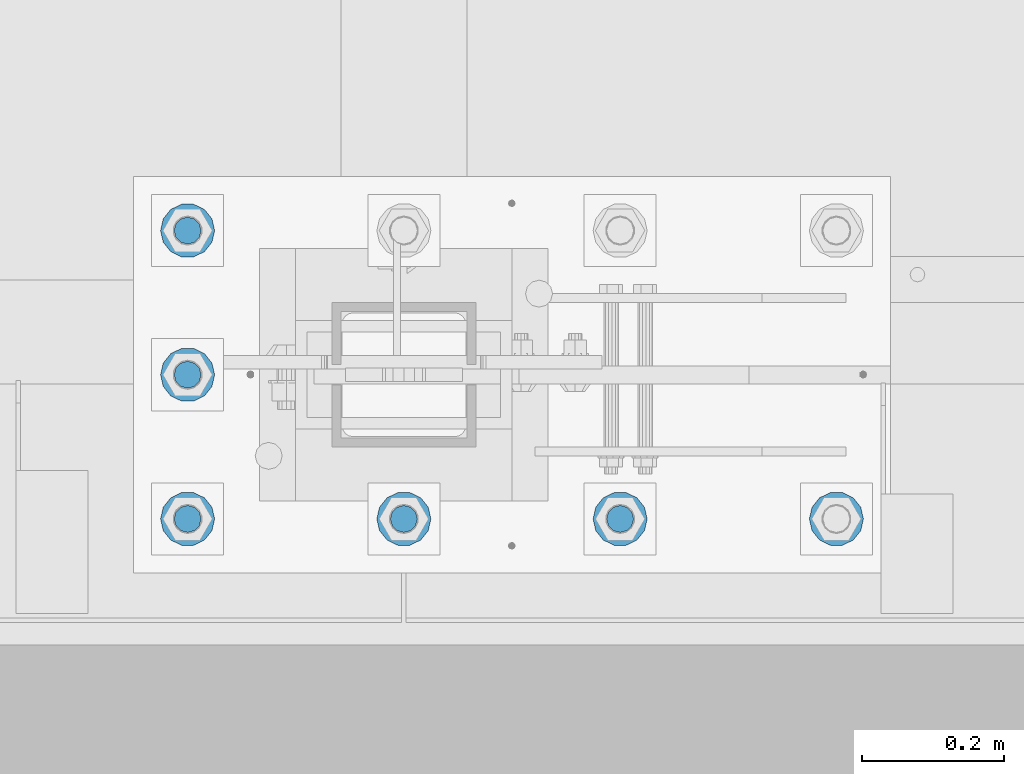
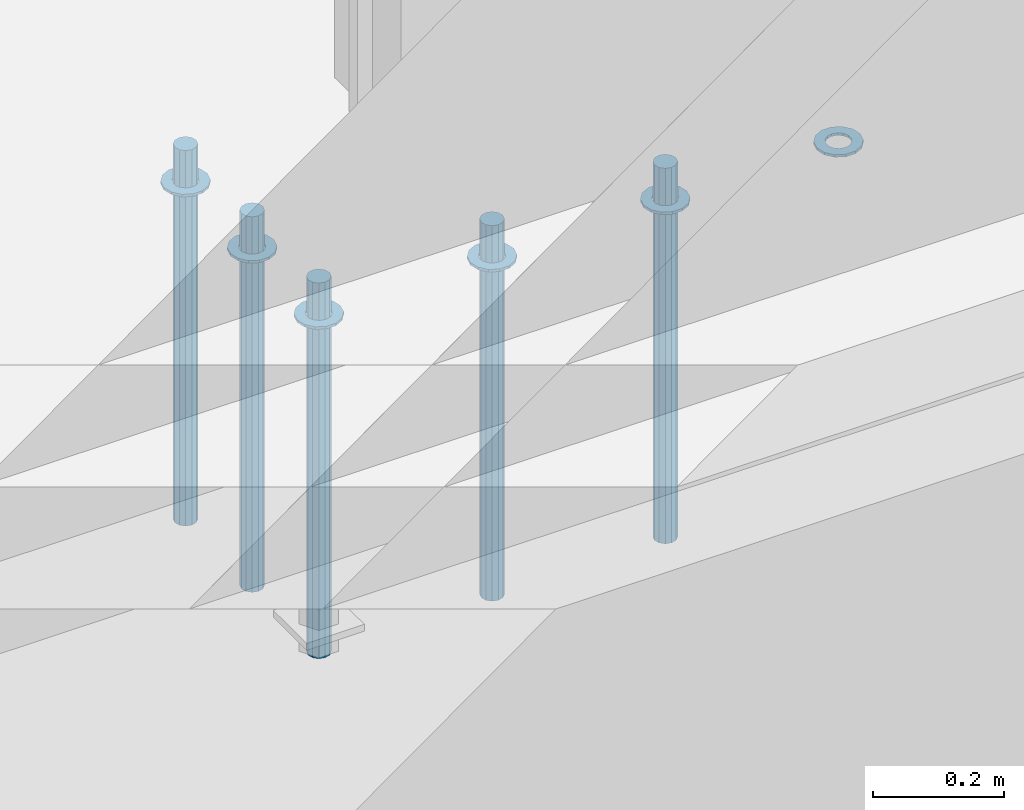
# One storey, part 931 of 1763: 11 columns, 1 element without a shape of its own.
"""IFC2X3 building model written with IfcOpenShell, lengths in millimetres."""

from ifc_helpers import new_model, si_unit, frame, origin_with_axes, place, context, subcontext, project, spatial, faceted_brep, material, type_object, element, aggregate, save


model = new_model("IFC2X3")

# Units and contexts
model_context = context("Model", 3, precision=1e-05, world=origin_with_axes())
body_context = subcontext(model_context, "Body", "Model", "MODEL_VIEW")
ifc_project = project(units=[si_unit("LENGTHUNIT", "METRE", prefix="MILLI"), si_unit("AREAUNIT", "SQUARE_METRE"), si_unit("VOLUMEUNIT", "CUBIC_METRE"), si_unit("MASSUNIT", "GRAM", prefix="KILO"), si_unit("TIMEUNIT", "SECOND"), si_unit("PLANEANGLEUNIT", "RADIAN"), si_unit("SOLIDANGLEUNIT", "STERADIAN"), si_unit("THERMODYNAMICTEMPERATUREUNIT", "DEGREE_CELSIUS"), si_unit("LUMINOUSINTENSITYUNIT", "LUMEN")], contexts=[model_context])

# Site, building, storey
site_placement = place(None, origin_with_axes())
site = spatial("IfcSite", under=ifc_project, at=site_placement, CompositionType="ELEMENT")
building_placement = place(site_placement, origin_with_axes())
building = spatial("IfcBuilding", under=site, at=building_placement, Name="Undefined", CompositionType="ELEMENT")
storey_placement = place(building_placement, origin_with_axes())
storey = spatial("IfcBuildingStorey", under=building, at=storey_placement, Name="Undefined", CompositionType="ELEMENT", Elevation=0.0)

# Assembly, columns
assembly_placement = place(storey_placement, origin_with_axes())
assembly = element("IfcElementAssembly", 1, at=assembly_placement, inside=storey, Name="TEMPLATE", AssemblyPlace="NOTDEFINED", PredefinedType="RIGID_FRAME")
ifc_material_1 = material(Name="STEEL/F436")
column_type_1 = type_object("IfcColumnType", Name="1-1/2_WASHER", PredefinedType="NOTDEFINED")
column_1_placement = place(assembly_placement, frame((-35254.6372736983, -13919.2, 5151.4375), z_axis=(0.0, -1.0, 0.0), x_axis=(0.0, 0.0, -1.0)))
column_1 = element("IfcColumn", 2, at=column_1_placement, type_object=column_type_1, material=ifc_material_1, Name="WASHER", ObjectType="1-1/2_WASHER", context=body_context, shape_type="Brep", body=[
    faceted_brep([(0.0, -38.0999984741211, 0.0), (0.0, -34.3269124923099, -16.5309697983248), (4.76249999999982, -34.3269124923099, -16.5309697983248), (4.76249999999982, -38.0999984741211, 0.0), (0.0, -23.7549604994492, -29.7877782890519), (4.76249999999982, -23.7549604994492, -29.7877782890519), (0.0, -8.47804724419257, -37.1447519665053), (4.76249999999982, -8.47804724419257, -37.1447519665053), (0.0, 8.47804724419257, -37.1447519665053), (4.76249999999982, 8.47804724419257, -37.1447519665053), (0.0, 23.7549604994492, -29.7877782890519), (4.76249999999982, 23.7549604994492, -29.7877782890519), (0.0, 34.3269124923099, -16.5309697983248), (4.76249999999982, 34.3269124923099, -16.5309697983248), (0.0, 38.0999984741211, 0.0), (4.76249999999982, 38.0999984741211, 0.0), (0.0, 34.3269124923099, 16.5309697983248), (4.76249999999982, 34.3269124923099, 16.5309697983248), (0.0, 23.7549604994492, 29.7877782890519), (4.76249999999982, 23.7549604994492, 29.7877782890519), (0.0, 8.47804724419257, 37.1447519665053), (4.76249999999982, 8.47804724419257, 37.1447519665053), (0.0, -8.47804724419257, 37.1447519665053), (4.76249999999982, -8.47804724419257, 37.1447519665053), (0.0, -23.7549604994492, 29.7877782890519), (4.76249999999982, -23.7549604994492, 29.7877782890519), (0.0, -34.3269124923099, 16.5309697983248), (4.76249999999982, -34.3269124923099, 16.5309697983248), (0.0, 0.0, 20.6399993896484), (0.0, 8.95536011056538, 18.5959968835978), (4.76249999999982, 8.95536011056538, 18.5959968835978), (4.76249999999982, 0.0, 20.6399993896484), (0.0, 16.1370013209453, 12.8688291298167), (4.76249999999982, 16.1370013209453, 12.8688291298167), (0.0, 20.1225115123816, 4.59283194104137), (4.76249999999982, 20.1225115123816, 4.59283194104137), (0.0, 20.1225115123816, -4.59283194104319), (4.76249999999982, 20.1225115123816, -4.59283194104319), (0.0, 16.1370013209453, -12.8688291298167), (4.76249999999982, 16.1370013209453, -12.8688291298167), (0.0, 8.95536011056538, -18.5959968835978), (4.76249999999982, 8.95536011056538, -18.5959968835978), (0.0, 0.0, -20.6399993896484), (4.76249999999982, 0.0, -20.6399993896484), (0.0, -8.95536011056538, -18.5959968835978), (4.76249999999982, -8.95536011056538, -18.5959968835978), (0.0, -16.1370013209453, -12.8688291298167), (4.76249999999982, -16.1370013209453, -12.8688291298167), (0.0, -20.1225115123816, -4.59283194104137), (4.76249999999982, -20.1225115123816, -4.59283194104137), (0.0, -20.1225115123816, 4.59283194104319), (4.76249999999982, -20.1225115123816, 4.59283194104319), (0.0, -16.1370013209453, 12.8688291298167), (4.76249999999982, -16.1370013209453, 12.8688291298167), (0.0, -8.95536011056538, 18.5959968835978), (4.76249999999982, -8.95536011056538, 18.5959968835978)], [[[0, 1, 2, 3]], [[1, 4, 5, 2]], [[4, 6, 7, 5]], [[6, 8, 9, 7]], [[8, 10, 11, 9]], [[10, 12, 13, 11]], [[12, 14, 15, 13]], [[14, 16, 17, 15]], [[16, 18, 19, 17]], [[18, 20, 21, 19]], [[20, 22, 23, 21]], [[22, 24, 25, 23]], [[24, 26, 27, 25]], [[26, 0, 3, 27]], [[28, 29, 30, 31]], [[29, 32, 33, 30]], [[32, 34, 35, 33]], [[34, 36, 37, 35]], [[36, 38, 39, 37]], [[38, 40, 41, 39]], [[40, 42, 43, 41]], [[42, 44, 45, 43]], [[44, 46, 47, 45]], [[46, 48, 49, 47]], [[48, 50, 51, 49]], [[50, 52, 53, 51]], [[52, 54, 55, 53]], [[54, 28, 31, 55]], [[5, 7, 9, 11, 13, 15, 17, 19, 21, 23, 25, 27, 3, 2], [33, 35, 37, 39, 41, 43, 45, 47, 49, 51, 53, 55, 31, 30]], [[26, 24, 22, 20, 18, 16, 14, 12, 10, 8, 6, 4, 1, 0], [54, 52, 50, 48, 46, 44, 42, 40, 38, 36, 34, 32, 29, 28]]]),
])
column_2_placement = place(assembly_placement, frame((-34949.8372736984, -13919.2, 5151.4375), z_axis=(0.0, -1.0, 0.0), x_axis=(0.0, 0.0, -1.0)))
column_2 = element("IfcColumn", 3, at=column_2_placement, type_object=column_type_1, material=ifc_material_1, Name="WASHER", ObjectType="1-1/2_WASHER", context=body_context, shape_type="Brep", body=[
    faceted_brep([(0.0, -38.0999984741211, 0.0), (0.0, -34.3269124923099, -16.5309697983248), (4.76249999999982, -34.3269124923099, -16.5309697983248), (4.76249999999982, -38.0999984741211, 0.0), (0.0, -23.7549604994492, -29.7877782890519), (4.76249999999982, -23.7549604994492, -29.7877782890519), (0.0, -8.47804724419257, -37.1447519665053), (4.76249999999982, -8.47804724419257, -37.1447519665053), (0.0, 8.47804724419257, -37.1447519665053), (4.76249999999982, 8.47804724419257, -37.1447519665053), (0.0, 23.7549604994492, -29.7877782890519), (4.76249999999982, 23.7549604994492, -29.7877782890519), (0.0, 34.3269124923099, -16.5309697983248), (4.76249999999982, 34.3269124923099, -16.5309697983248), (0.0, 38.0999984741211, 0.0), (4.76249999999982, 38.0999984741211, 0.0), (0.0, 34.3269124923099, 16.5309697983248), (4.76249999999982, 34.3269124923099, 16.5309697983248), (0.0, 23.7549604994492, 29.7877782890519), (4.76249999999982, 23.7549604994492, 29.7877782890519), (0.0, 8.47804724419257, 37.1447519665053), (4.76249999999982, 8.47804724419257, 37.1447519665053), (0.0, -8.47804724419257, 37.1447519665053), (4.76249999999982, -8.47804724419257, 37.1447519665053), (0.0, -23.7549604994492, 29.7877782890519), (4.76249999999982, -23.7549604994492, 29.7877782890519), (0.0, -34.3269124923099, 16.5309697983248), (4.76249999999982, -34.3269124923099, 16.5309697983248), (0.0, 0.0, 20.6399993896484), (0.0, 8.95536011056538, 18.5959968835978), (4.76249999999982, 8.95536011056538, 18.5959968835978), (4.76249999999982, 0.0, 20.6399993896484), (0.0, 16.1370013209453, 12.8688291298167), (4.76249999999982, 16.1370013209453, 12.8688291298167), (0.0, 20.1225115123816, 4.59283194104137), (4.76249999999982, 20.1225115123816, 4.59283194104137), (0.0, 20.1225115123816, -4.59283194104319), (4.76249999999982, 20.1225115123816, -4.59283194104319), (0.0, 16.1370013209453, -12.8688291298167), (4.76249999999982, 16.1370013209453, -12.8688291298167), (0.0, 8.95536011056538, -18.5959968835978), (4.76249999999982, 8.95536011056538, -18.5959968835978), (0.0, 0.0, -20.6399993896484), (4.76249999999982, 0.0, -20.6399993896484), (0.0, -8.95536011056538, -18.5959968835978), (4.76249999999982, -8.95536011056538, -18.5959968835978), (0.0, -16.1370013209453, -12.8688291298167), (4.76249999999982, -16.1370013209453, -12.8688291298167), (0.0, -20.1225115123816, -4.59283194104137), (4.76249999999982, -20.1225115123816, -4.59283194104137), (0.0, -20.1225115123816, 4.59283194104319), (4.76249999999982, -20.1225115123816, 4.59283194104319), (0.0, -16.1370013209453, 12.8688291298167), (4.76249999999982, -16.1370013209453, 12.8688291298167), (0.0, -8.95536011056538, 18.5959968835978), (4.76249999999982, -8.95536011056538, 18.5959968835978)], [[[0, 1, 2, 3]], [[1, 4, 5, 2]], [[4, 6, 7, 5]], [[6, 8, 9, 7]], [[8, 10, 11, 9]], [[10, 12, 13, 11]], [[12, 14, 15, 13]], [[14, 16, 17, 15]], [[16, 18, 19, 17]], [[18, 20, 21, 19]], [[20, 22, 23, 21]], [[22, 24, 25, 23]], [[24, 26, 27, 25]], [[26, 0, 3, 27]], [[28, 29, 30, 31]], [[29, 32, 33, 30]], [[32, 34, 35, 33]], [[34, 36, 37, 35]], [[36, 38, 39, 37]], [[38, 40, 41, 39]], [[40, 42, 43, 41]], [[42, 44, 45, 43]], [[44, 46, 47, 45]], [[46, 48, 49, 47]], [[48, 50, 51, 49]], [[50, 52, 53, 51]], [[52, 54, 55, 53]], [[54, 28, 31, 55]], [[5, 7, 9, 11, 13, 15, 17, 19, 21, 23, 25, 27, 3, 2], [33, 35, 37, 39, 41, 43, 45, 47, 49, 51, 53, 55, 31, 30]], [[26, 24, 22, 20, 18, 16, 14, 12, 10, 8, 6, 4, 1, 0], [54, 52, 50, 48, 46, 44, 42, 40, 38, 36, 34, 32, 29, 28]]]),
])
column_3_placement = place(assembly_placement, frame((-34645.0372736983, -13919.2, 5151.4375), z_axis=(0.0, 1.0, 0.0), x_axis=(0.0, 0.0, -1.0)))
column_3 = element("IfcColumn", 4, at=column_3_placement, type_object=column_type_1, material=ifc_material_1, Name="WASHER", ObjectType="1-1/2_WASHER", context=body_context, shape_type="Brep", body=[
    faceted_brep([(0.0, -38.0999984741211, 0.0), (0.0, -34.3269124923099, -16.5309697983248), (4.76249999999982, -34.3269124923099, -16.5309697983248), (4.76249999999982, -38.0999984741211, 0.0), (0.0, -23.7549604994492, -29.7877782890519), (4.76249999999982, -23.7549604994492, -29.7877782890519), (0.0, -8.47804724419257, -37.1447519665053), (4.76249999999982, -8.47804724419257, -37.1447519665053), (0.0, 8.47804724419257, -37.1447519665053), (4.76249999999982, 8.47804724419257, -37.1447519665053), (0.0, 23.7549604994492, -29.7877782890519), (4.76249999999982, 23.7549604994492, -29.7877782890519), (0.0, 34.3269124923099, -16.5309697983248), (4.76249999999982, 34.3269124923099, -16.5309697983248), (0.0, 38.0999984741211, 0.0), (4.76249999999982, 38.0999984741211, 0.0), (0.0, 34.3269124923099, 16.5309697983248), (4.76249999999982, 34.3269124923099, 16.5309697983248), (0.0, 23.7549604994492, 29.7877782890519), (4.76249999999982, 23.7549604994492, 29.7877782890519), (0.0, 8.47804724419257, 37.1447519665053), (4.76249999999982, 8.47804724419257, 37.1447519665053), (0.0, -8.47804724419257, 37.1447519665053), (4.76249999999982, -8.47804724419257, 37.1447519665053), (0.0, -23.7549604994492, 29.7877782890519), (4.76249999999982, -23.7549604994492, 29.7877782890519), (0.0, -34.3269124923099, 16.5309697983248), (4.76249999999982, -34.3269124923099, 16.5309697983248), (0.0, 0.0, 20.6399993896484), (0.0, 8.95536011056538, 18.5959968835978), (4.76249999999982, 8.95536011056538, 18.5959968835978), (4.76249999999982, 0.0, 20.6399993896484), (0.0, 16.1370013209453, 12.8688291298167), (4.76249999999982, 16.1370013209453, 12.8688291298167), (0.0, 20.1225115123816, 4.59283194104137), (4.76249999999982, 20.1225115123816, 4.59283194104137), (0.0, 20.1225115123816, -4.59283194104319), (4.76249999999982, 20.1225115123816, -4.59283194104319), (0.0, 16.1370013209453, -12.8688291298167), (4.76249999999982, 16.1370013209453, -12.8688291298167), (0.0, 8.95536011056538, -18.5959968835978), (4.76249999999982, 8.95536011056538, -18.5959968835978), (0.0, 0.0, -20.6399993896484), (4.76249999999982, 0.0, -20.6399993896484), (0.0, -8.95536011056538, -18.5959968835978), (4.76249999999982, -8.95536011056538, -18.5959968835978), (0.0, -16.1370013209453, -12.8688291298167), (4.76249999999982, -16.1370013209453, -12.8688291298167), (0.0, -20.1225115123816, -4.59283194104137), (4.76249999999982, -20.1225115123816, -4.59283194104137), (0.0, -20.1225115123816, 4.59283194104319), (4.76249999999982, -20.1225115123816, 4.59283194104319), (0.0, -16.1370013209453, 12.8688291298167), (4.76249999999982, -16.1370013209453, 12.8688291298167), (0.0, -8.95536011056538, 18.5959968835978), (4.76249999999982, -8.95536011056538, 18.5959968835978)], [[[0, 1, 2, 3]], [[1, 4, 5, 2]], [[4, 6, 7, 5]], [[6, 8, 9, 7]], [[8, 10, 11, 9]], [[10, 12, 13, 11]], [[12, 14, 15, 13]], [[14, 16, 17, 15]], [[16, 18, 19, 17]], [[18, 20, 21, 19]], [[20, 22, 23, 21]], [[22, 24, 25, 23]], [[24, 26, 27, 25]], [[26, 0, 3, 27]], [[28, 29, 30, 31]], [[29, 32, 33, 30]], [[32, 34, 35, 33]], [[34, 36, 37, 35]], [[36, 38, 39, 37]], [[38, 40, 41, 39]], [[40, 42, 43, 41]], [[42, 44, 45, 43]], [[44, 46, 47, 45]], [[46, 48, 49, 47]], [[48, 50, 51, 49]], [[50, 52, 53, 51]], [[52, 54, 55, 53]], [[54, 28, 31, 55]], [[5, 7, 9, 11, 13, 15, 17, 19, 21, 23, 25, 27, 3, 2], [33, 35, 37, 39, 41, 43, 45, 47, 49, 51, 53, 55, 31, 30]], [[26, 24, 22, 20, 18, 16, 14, 12, 10, 8, 6, 4, 1, 0], [54, 52, 50, 48, 46, 44, 42, 40, 38, 36, 34, 32, 29, 28]]]),
])
column_4_placement = place(assembly_placement, frame((-34340.2372736983, -13919.2, 5151.4375), z_axis=(0.0, 1.0, 0.0), x_axis=(0.0, 0.0, -1.0)))
column_4 = element("IfcColumn", 5, at=column_4_placement, type_object=column_type_1, material=ifc_material_1, Name="WASHER", ObjectType="1-1/2_WASHER", context=body_context, shape_type="Brep", body=[
    faceted_brep([(0.0, -38.0999984741211, 0.0), (0.0, -34.3269124923099, -16.5309697983248), (4.76249999999982, -34.3269124923099, -16.5309697983248), (4.76249999999982, -38.0999984741211, 0.0), (0.0, -23.7549604994492, -29.7877782890519), (4.76249999999982, -23.7549604994492, -29.7877782890519), (0.0, -8.47804724419257, -37.1447519665053), (4.76249999999982, -8.47804724419257, -37.1447519665053), (0.0, 8.47804724419257, -37.1447519665053), (4.76249999999982, 8.47804724419257, -37.1447519665053), (0.0, 23.7549604994492, -29.7877782890519), (4.76249999999982, 23.7549604994492, -29.7877782890519), (0.0, 34.3269124923099, -16.5309697983248), (4.76249999999982, 34.3269124923099, -16.5309697983248), (0.0, 38.0999984741211, 0.0), (4.76249999999982, 38.0999984741211, 0.0), (0.0, 34.3269124923099, 16.5309697983248), (4.76249999999982, 34.3269124923099, 16.5309697983248), (0.0, 23.7549604994492, 29.7877782890519), (4.76249999999982, 23.7549604994492, 29.7877782890519), (0.0, 8.47804724419257, 37.1447519665053), (4.76249999999982, 8.47804724419257, 37.1447519665053), (0.0, -8.47804724419257, 37.1447519665053), (4.76249999999982, -8.47804724419257, 37.1447519665053), (0.0, -23.7549604994492, 29.7877782890519), (4.76249999999982, -23.7549604994492, 29.7877782890519), (0.0, -34.3269124923099, 16.5309697983248), (4.76249999999982, -34.3269124923099, 16.5309697983248), (0.0, 0.0, 20.6399993896484), (0.0, 8.95536011056538, 18.5959968835978), (4.76249999999982, 8.95536011056538, 18.5959968835978), (4.76249999999982, 0.0, 20.6399993896484), (0.0, 16.1370013209453, 12.8688291298167), (4.76249999999982, 16.1370013209453, 12.8688291298167), (0.0, 20.1225115123816, 4.59283194104137), (4.76249999999982, 20.1225115123816, 4.59283194104137), (0.0, 20.1225115123816, -4.59283194104319), (4.76249999999982, 20.1225115123816, -4.59283194104319), (0.0, 16.1370013209453, -12.8688291298167), (4.76249999999982, 16.1370013209453, -12.8688291298167), (0.0, 8.95536011056538, -18.5959968835978), (4.76249999999982, 8.95536011056538, -18.5959968835978), (0.0, 0.0, -20.6399993896484), (4.76249999999982, 0.0, -20.6399993896484), (0.0, -8.95536011056538, -18.5959968835978), (4.76249999999982, -8.95536011056538, -18.5959968835978), (0.0, -16.1370013209453, -12.8688291298167), (4.76249999999982, -16.1370013209453, -12.8688291298167), (0.0, -20.1225115123816, -4.59283194104137), (4.76249999999982, -20.1225115123816, -4.59283194104137), (0.0, -20.1225115123816, 4.59283194104319), (4.76249999999982, -20.1225115123816, 4.59283194104319), (0.0, -16.1370013209453, 12.8688291298167), (4.76249999999982, -16.1370013209453, 12.8688291298167), (0.0, -8.95536011056538, 18.5959968835978), (4.76249999999982, -8.95536011056538, 18.5959968835978)], [[[0, 1, 2, 3]], [[1, 4, 5, 2]], [[4, 6, 7, 5]], [[6, 8, 9, 7]], [[8, 10, 11, 9]], [[10, 12, 13, 11]], [[12, 14, 15, 13]], [[14, 16, 17, 15]], [[16, 18, 19, 17]], [[18, 20, 21, 19]], [[20, 22, 23, 21]], [[22, 24, 25, 23]], [[24, 26, 27, 25]], [[26, 0, 3, 27]], [[28, 29, 30, 31]], [[29, 32, 33, 30]], [[32, 34, 35, 33]], [[34, 36, 37, 35]], [[36, 38, 39, 37]], [[38, 40, 41, 39]], [[40, 42, 43, 41]], [[42, 44, 45, 43]], [[44, 46, 47, 45]], [[46, 48, 49, 47]], [[48, 50, 51, 49]], [[50, 52, 53, 51]], [[52, 54, 55, 53]], [[54, 28, 31, 55]], [[5, 7, 9, 11, 13, 15, 17, 19, 21, 23, 25, 27, 3, 2], [33, 35, 37, 39, 41, 43, 45, 47, 49, 51, 53, 55, 31, 30]], [[26, 24, 22, 20, 18, 16, 14, 12, 10, 8, 6, 4, 1, 0], [54, 52, 50, 48, 46, 44, 42, 40, 38, 36, 34, 32, 29, 28]]]),
])
column_5_placement = place(assembly_placement, frame((-35254.6372736983, -13716.0, 5151.4375), z_axis=(0.0, -1.0, 0.0), x_axis=(0.0, 0.0, -1.0)))
column_5 = element("IfcColumn", 6, at=column_5_placement, type_object=column_type_1, material=ifc_material_1, Name="WASHER", ObjectType="1-1/2_WASHER", context=body_context, shape_type="Brep", body=[
    faceted_brep([(0.0, -38.0999984741211, 0.0), (0.0, -34.3269124923099, -16.5309697983248), (4.76249999999982, -34.3269124923099, -16.5309697983248), (4.76249999999982, -38.0999984741211, 0.0), (0.0, -23.7549604994492, -29.7877782890519), (4.76249999999982, -23.7549604994492, -29.7877782890519), (0.0, -8.47804724419257, -37.1447519665053), (4.76249999999982, -8.47804724419257, -37.1447519665053), (0.0, 8.47804724419257, -37.1447519665053), (4.76249999999982, 8.47804724419257, -37.1447519665053), (0.0, 23.7549604994492, -29.7877782890519), (4.76249999999982, 23.7549604994492, -29.7877782890519), (0.0, 34.3269124923099, -16.5309697983248), (4.76249999999982, 34.3269124923099, -16.5309697983248), (0.0, 38.0999984741211, 0.0), (4.76249999999982, 38.0999984741211, 0.0), (0.0, 34.3269124923099, 16.5309697983248), (4.76249999999982, 34.3269124923099, 16.5309697983248), (0.0, 23.7549604994492, 29.7877782890519), (4.76249999999982, 23.7549604994492, 29.7877782890519), (0.0, 8.47804724419257, 37.1447519665053), (4.76249999999982, 8.47804724419257, 37.1447519665053), (0.0, -8.47804724419257, 37.1447519665053), (4.76249999999982, -8.47804724419257, 37.1447519665053), (0.0, -23.7549604994492, 29.7877782890519), (4.76249999999982, -23.7549604994492, 29.7877782890519), (0.0, -34.3269124923099, 16.5309697983248), (4.76249999999982, -34.3269124923099, 16.5309697983248), (0.0, 0.0, 20.6399993896484), (0.0, 8.95536011056538, 18.5959968835978), (4.76249999999982, 8.95536011056538, 18.5959968835978), (4.76249999999982, 0.0, 20.6399993896484), (0.0, 16.1370013209453, 12.8688291298167), (4.76249999999982, 16.1370013209453, 12.8688291298167), (0.0, 20.1225115123816, 4.59283194104137), (4.76249999999982, 20.1225115123816, 4.59283194104137), (0.0, 20.1225115123816, -4.59283194104319), (4.76249999999982, 20.1225115123816, -4.59283194104319), (0.0, 16.1370013209453, -12.8688291298167), (4.76249999999982, 16.1370013209453, -12.8688291298167), (0.0, 8.95536011056538, -18.5959968835978), (4.76249999999982, 8.95536011056538, -18.5959968835978), (0.0, 0.0, -20.6399993896484), (4.76249999999982, 0.0, -20.6399993896484), (0.0, -8.95536011056538, -18.5959968835978), (4.76249999999982, -8.95536011056538, -18.5959968835978), (0.0, -16.1370013209453, -12.8688291298167), (4.76249999999982, -16.1370013209453, -12.8688291298167), (0.0, -20.1225115123816, -4.59283194104137), (4.76249999999982, -20.1225115123816, -4.59283194104137), (0.0, -20.1225115123816, 4.59283194104319), (4.76249999999982, -20.1225115123816, 4.59283194104319), (0.0, -16.1370013209453, 12.8688291298167), (4.76249999999982, -16.1370013209453, 12.8688291298167), (0.0, -8.95536011056538, 18.5959968835978), (4.76249999999982, -8.95536011056538, 18.5959968835978)], [[[0, 1, 2, 3]], [[1, 4, 5, 2]], [[4, 6, 7, 5]], [[6, 8, 9, 7]], [[8, 10, 11, 9]], [[10, 12, 13, 11]], [[12, 14, 15, 13]], [[14, 16, 17, 15]], [[16, 18, 19, 17]], [[18, 20, 21, 19]], [[20, 22, 23, 21]], [[22, 24, 25, 23]], [[24, 26, 27, 25]], [[26, 0, 3, 27]], [[28, 29, 30, 31]], [[29, 32, 33, 30]], [[32, 34, 35, 33]], [[34, 36, 37, 35]], [[36, 38, 39, 37]], [[38, 40, 41, 39]], [[40, 42, 43, 41]], [[42, 44, 45, 43]], [[44, 46, 47, 45]], [[46, 48, 49, 47]], [[48, 50, 51, 49]], [[50, 52, 53, 51]], [[52, 54, 55, 53]], [[54, 28, 31, 55]], [[5, 7, 9, 11, 13, 15, 17, 19, 21, 23, 25, 27, 3, 2], [33, 35, 37, 39, 41, 43, 45, 47, 49, 51, 53, 55, 31, 30]], [[26, 24, 22, 20, 18, 16, 14, 12, 10, 8, 6, 4, 1, 0], [54, 52, 50, 48, 46, 44, 42, 40, 38, 36, 34, 32, 29, 28]]]),
])
column_6_placement = place(assembly_placement, frame((-35254.6372736983, -13512.8, 5151.4375), z_axis=(0.0, -1.0, 0.0), x_axis=(0.0, 0.0, -1.0)))
column_6 = element("IfcColumn", 7, at=column_6_placement, type_object=column_type_1, material=ifc_material_1, Name="WASHER", ObjectType="1-1/2_WASHER", context=body_context, shape_type="Brep", body=[
    faceted_brep([(0.0, -38.0999984741211, 0.0), (0.0, -34.3269124923099, -16.5309697983248), (4.76249999999982, -34.3269124923099, -16.5309697983248), (4.76249999999982, -38.0999984741211, 0.0), (0.0, -23.7549604994492, -29.7877782890519), (4.76249999999982, -23.7549604994492, -29.7877782890519), (0.0, -8.47804724419257, -37.1447519665053), (4.76249999999982, -8.47804724419257, -37.1447519665053), (0.0, 8.47804724419257, -37.1447519665053), (4.76249999999982, 8.47804724419257, -37.1447519665053), (0.0, 23.7549604994492, -29.7877782890519), (4.76249999999982, 23.7549604994492, -29.7877782890519), (0.0, 34.3269124923099, -16.5309697983248), (4.76249999999982, 34.3269124923099, -16.5309697983248), (0.0, 38.0999984741211, 0.0), (4.76249999999982, 38.0999984741211, 0.0), (0.0, 34.3269124923099, 16.5309697983248), (4.76249999999982, 34.3269124923099, 16.5309697983248), (0.0, 23.7549604994492, 29.7877782890519), (4.76249999999982, 23.7549604994492, 29.7877782890519), (0.0, 8.47804724419257, 37.1447519665053), (4.76249999999982, 8.47804724419257, 37.1447519665053), (0.0, -8.47804724419257, 37.1447519665053), (4.76249999999982, -8.47804724419257, 37.1447519665053), (0.0, -23.7549604994492, 29.7877782890519), (4.76249999999982, -23.7549604994492, 29.7877782890519), (0.0, -34.3269124923099, 16.5309697983248), (4.76249999999982, -34.3269124923099, 16.5309697983248), (0.0, 0.0, 20.6399993896484), (0.0, 8.95536011056538, 18.5959968835978), (4.76249999999982, 8.95536011056538, 18.5959968835978), (4.76249999999982, 0.0, 20.6399993896484), (0.0, 16.1370013209453, 12.8688291298167), (4.76249999999982, 16.1370013209453, 12.8688291298167), (0.0, 20.1225115123816, 4.59283194104137), (4.76249999999982, 20.1225115123816, 4.59283194104137), (0.0, 20.1225115123816, -4.59283194104319), (4.76249999999982, 20.1225115123816, -4.59283194104319), (0.0, 16.1370013209453, -12.8688291298167), (4.76249999999982, 16.1370013209453, -12.8688291298167), (0.0, 8.95536011056538, -18.5959968835978), (4.76249999999982, 8.95536011056538, -18.5959968835978), (0.0, 0.0, -20.6399993896484), (4.76249999999982, 0.0, -20.6399993896484), (0.0, -8.95536011056538, -18.5959968835978), (4.76249999999982, -8.95536011056538, -18.5959968835978), (0.0, -16.1370013209453, -12.8688291298167), (4.76249999999982, -16.1370013209453, -12.8688291298167), (0.0, -20.1225115123816, -4.59283194104137), (4.76249999999982, -20.1225115123816, -4.59283194104137), (0.0, -20.1225115123816, 4.59283194104319), (4.76249999999982, -20.1225115123816, 4.59283194104319), (0.0, -16.1370013209453, 12.8688291298167), (4.76249999999982, -16.1370013209453, 12.8688291298167), (0.0, -8.95536011056538, 18.5959968835978), (4.76249999999982, -8.95536011056538, 18.5959968835978)], [[[0, 1, 2, 3]], [[1, 4, 5, 2]], [[4, 6, 7, 5]], [[6, 8, 9, 7]], [[8, 10, 11, 9]], [[10, 12, 13, 11]], [[12, 14, 15, 13]], [[14, 16, 17, 15]], [[16, 18, 19, 17]], [[18, 20, 21, 19]], [[20, 22, 23, 21]], [[22, 24, 25, 23]], [[24, 26, 27, 25]], [[26, 0, 3, 27]], [[28, 29, 30, 31]], [[29, 32, 33, 30]], [[32, 34, 35, 33]], [[34, 36, 37, 35]], [[36, 38, 39, 37]], [[38, 40, 41, 39]], [[40, 42, 43, 41]], [[42, 44, 45, 43]], [[44, 46, 47, 45]], [[46, 48, 49, 47]], [[48, 50, 51, 49]], [[50, 52, 53, 51]], [[52, 54, 55, 53]], [[54, 28, 31, 55]], [[5, 7, 9, 11, 13, 15, 17, 19, 21, 23, 25, 27, 3, 2], [33, 35, 37, 39, 41, 43, 45, 47, 49, 51, 53, 55, 31, 30]], [[26, 24, 22, 20, 18, 16, 14, 12, 10, 8, 6, 4, 1, 0], [54, 52, 50, 48, 46, 44, 42, 40, 38, 36, 34, 32, 29, 28]]]),
])
ifc_material_2 = material(Name="STEEL/F1554-GR.55")
column_type_2 = type_object("IfcColumnType", PredefinedType="NOTDEFINED")
column_7_placement = place(assembly_placement, frame((-35254.6372736983, -13919.2, 5219.7), z_axis=(0.0, -1.0, 0.0), x_axis=(0.0, 0.0, -1.0)))
column_7 = element("IfcColumn", 8, at=column_7_placement, type_object=column_type_2, material=ifc_material_2, Name="ALL THREADED ROD", context=body_context, shape_type="Brep", body=[
    faceted_brep([(0.0, -19.0500000000029, 0.0), (0.0, -16.4977839420899, -9.52500000000146), (698.499, -16.4977839420972, -9.52499999999964), (698.499, -19.0500000000029, 0.0), (0.0, -9.52499999999418, -16.4977839420935), (698.499, -9.52500000000146, -16.4977839420935), (1.45519152283669e-11, 1.81898940354586e-12, -19.0499999999993), (698.499, 0.0, -19.0499999999993), (0.0, 9.52499999999418, -16.4977839420935), (698.499, 9.52500000000146, -16.4977839420935), (0.0, 16.4977839420899, -9.52500000000146), (698.499, 16.4977839420972, -9.52499999999964), (0.0, 19.0500000000029, 0.0), (698.499, 19.0500000000029, 0.0), (0.0, 16.4977839420899, 9.52500000000146), (698.499, 16.4977839420972, 9.52499999999964), (0.0, 9.52499999999418, 16.4977839420935), (698.499, 9.52500000000146, 16.4977839420935), (1.45519152283669e-11, 1.81898940354586e-12, 19.0499999999993), (698.499, 0.0, 19.0499999999993), (0.0, -9.52499999999418, 16.4977839420935), (698.499, -9.52500000000146, 16.4977839420935), (0.0, -16.4977839420899, 9.52500000000146), (698.499, -16.4977839420972, 9.52499999999964)], [[[0, 1, 2, 3]], [[1, 4, 5, 2]], [[4, 6, 7, 5]], [[6, 8, 9, 7]], [[8, 10, 11, 9]], [[10, 12, 13, 11]], [[12, 14, 15, 13]], [[14, 16, 17, 15]], [[16, 18, 19, 17]], [[18, 20, 21, 19]], [[20, 22, 23, 21]], [[22, 0, 3, 23]], [[5, 7, 9, 11, 13, 15, 17, 19, 21, 23, 3, 2]], [[22, 20, 18, 16, 14, 12, 10, 8, 6, 4, 1, 0]]]),
])
column_8_placement = place(assembly_placement, frame((-34949.8372736984, -13919.2, 5219.7), z_axis=(0.0, -1.0, 0.0), x_axis=(0.0, 0.0, -1.0)))
column_8 = element("IfcColumn", 9, at=column_8_placement, type_object=column_type_2, material=ifc_material_2, Name="ALL THREADED ROD", context=body_context, shape_type="Brep", body=[
    faceted_brep([(0.0, -19.0500000000029, 0.0), (0.0, -16.4977839420899, -9.52500000000146), (698.499, -16.4977839420972, -9.52499999999964), (698.499, -19.0500000000029, 0.0), (0.0, -9.52499999999418, -16.4977839420935), (698.499, -9.52500000000146, -16.4977839420935), (1.45519152283669e-11, 1.81898940354586e-12, -19.0499999999993), (698.499, 0.0, -19.0499999999993), (0.0, 9.52499999999418, -16.4977839420935), (698.499, 9.52500000000146, -16.4977839420935), (0.0, 16.4977839420899, -9.52500000000146), (698.499, 16.4977839420972, -9.52499999999964), (0.0, 19.0500000000029, 0.0), (698.499, 19.0500000000029, 0.0), (0.0, 16.4977839420899, 9.52500000000146), (698.499, 16.4977839420972, 9.52499999999964), (0.0, 9.52499999999418, 16.4977839420935), (698.499, 9.52500000000146, 16.4977839420935), (1.45519152283669e-11, 1.81898940354586e-12, 19.0499999999993), (698.499, 0.0, 19.0499999999993), (0.0, -9.52499999999418, 16.4977839420935), (698.499, -9.52500000000146, 16.4977839420935), (0.0, -16.4977839420899, 9.52500000000146), (698.499, -16.4977839420972, 9.52499999999964)], [[[0, 1, 2, 3]], [[1, 4, 5, 2]], [[4, 6, 7, 5]], [[6, 8, 9, 7]], [[8, 10, 11, 9]], [[10, 12, 13, 11]], [[12, 14, 15, 13]], [[14, 16, 17, 15]], [[16, 18, 19, 17]], [[18, 20, 21, 19]], [[20, 22, 23, 21]], [[22, 0, 3, 23]], [[5, 7, 9, 11, 13, 15, 17, 19, 21, 23, 3, 2]], [[22, 20, 18, 16, 14, 12, 10, 8, 6, 4, 1, 0]]]),
])
column_9_placement = place(assembly_placement, frame((-34645.0372736983, -13919.2, 5219.7), z_axis=(0.0, 1.0, 0.0), x_axis=(0.0, 0.0, -1.0)))
column_9 = element("IfcColumn", 10, at=column_9_placement, type_object=column_type_2, material=ifc_material_2, Name="ALL THREADED ROD", context=body_context, shape_type="Brep", body=[
    faceted_brep([(0.0, -19.0500000000029, 0.0), (0.0, -16.4977839420899, -9.52500000000146), (698.499, -16.4977839420972, -9.52499999999964), (698.499, -19.0500000000029, 0.0), (0.0, -9.52499999999418, -16.4977839420935), (698.499, -9.52500000000146, -16.4977839420935), (1.45519152283669e-11, 1.81898940354586e-12, -19.0499999999993), (698.499, 0.0, -19.0499999999993), (0.0, 9.52499999999418, -16.4977839420935), (698.499, 9.52500000000146, -16.4977839420935), (0.0, 16.4977839420899, -9.52500000000146), (698.499, 16.4977839420972, -9.52499999999964), (0.0, 19.0500000000029, 0.0), (698.499, 19.0500000000029, 0.0), (0.0, 16.4977839420899, 9.52500000000146), (698.499, 16.4977839420972, 9.52499999999964), (0.0, 9.52499999999418, 16.4977839420935), (698.499, 9.52500000000146, 16.4977839420935), (1.45519152283669e-11, 1.81898940354586e-12, 19.0499999999993), (698.499, 0.0, 19.0499999999993), (0.0, -9.52499999999418, 16.4977839420935), (698.499, -9.52500000000146, 16.4977839420935), (0.0, -16.4977839420899, 9.52500000000146), (698.499, -16.4977839420972, 9.52499999999964)], [[[0, 1, 2, 3]], [[1, 4, 5, 2]], [[4, 6, 7, 5]], [[6, 8, 9, 7]], [[8, 10, 11, 9]], [[10, 12, 13, 11]], [[12, 14, 15, 13]], [[14, 16, 17, 15]], [[16, 18, 19, 17]], [[18, 20, 21, 19]], [[20, 22, 23, 21]], [[22, 0, 3, 23]], [[5, 7, 9, 11, 13, 15, 17, 19, 21, 23, 3, 2]], [[22, 20, 18, 16, 14, 12, 10, 8, 6, 4, 1, 0]]]),
])
column_10_placement = place(assembly_placement, frame((-35254.6372736983, -13716.0, 5219.7), z_axis=(0.0, -1.0, 0.0), x_axis=(0.0, 0.0, -1.0)))
column_10 = element("IfcColumn", 11, at=column_10_placement, type_object=column_type_2, material=ifc_material_2, Name="ALL THREADED ROD", context=body_context, shape_type="Brep", body=[
    faceted_brep([(0.0, -19.0500000000029, 0.0), (0.0, -16.4977839420899, -9.52500000000146), (698.499, -16.4977839420972, -9.52499999999964), (698.499, -19.0500000000029, 0.0), (0.0, -9.52499999999418, -16.4977839420935), (698.499, -9.52500000000146, -16.4977839420935), (1.45519152283669e-11, 1.81898940354586e-12, -19.0499999999993), (698.499, 0.0, -19.0499999999993), (0.0, 9.52499999999418, -16.4977839420935), (698.499, 9.52500000000146, -16.4977839420935), (0.0, 16.4977839420899, -9.52500000000146), (698.499, 16.4977839420972, -9.52499999999964), (0.0, 19.0500000000029, 0.0), (698.499, 19.0500000000029, 0.0), (0.0, 16.4977839420899, 9.52500000000146), (698.499, 16.4977839420972, 9.52499999999964), (0.0, 9.52499999999418, 16.4977839420935), (698.499, 9.52500000000146, 16.4977839420935), (1.45519152283669e-11, 1.81898940354586e-12, 19.0499999999993), (698.499, 0.0, 19.0499999999993), (0.0, -9.52499999999418, 16.4977839420935), (698.499, -9.52500000000146, 16.4977839420935), (0.0, -16.4977839420899, 9.52500000000146), (698.499, -16.4977839420972, 9.52499999999964)], [[[0, 1, 2, 3]], [[1, 4, 5, 2]], [[4, 6, 7, 5]], [[6, 8, 9, 7]], [[8, 10, 11, 9]], [[10, 12, 13, 11]], [[12, 14, 15, 13]], [[14, 16, 17, 15]], [[16, 18, 19, 17]], [[18, 20, 21, 19]], [[20, 22, 23, 21]], [[22, 0, 3, 23]], [[5, 7, 9, 11, 13, 15, 17, 19, 21, 23, 3, 2]], [[22, 20, 18, 16, 14, 12, 10, 8, 6, 4, 1, 0]]]),
])
column_11_placement = place(assembly_placement, frame((-35254.6372736983, -13512.8, 5219.7), z_axis=(0.0, -1.0, 0.0), x_axis=(0.0, 0.0, -1.0)))
column_11 = element("IfcColumn", 12, at=column_11_placement, type_object=column_type_2, material=ifc_material_2, Name="ALL THREADED ROD", context=body_context, shape_type="Brep", body=[
    faceted_brep([(0.0, -19.0500000000029, 0.0), (0.0, -16.4977839420899, -9.52500000000146), (698.499, -16.4977839420972, -9.52499999999964), (698.499, -19.0500000000029, 0.0), (0.0, -9.52499999999418, -16.4977839420935), (698.499, -9.52500000000146, -16.4977839420935), (1.45519152283669e-11, 1.81898940354586e-12, -19.0499999999993), (698.499, 0.0, -19.0499999999993), (0.0, 9.52499999999418, -16.4977839420935), (698.499, 9.52500000000146, -16.4977839420935), (0.0, 16.4977839420899, -9.52500000000146), (698.499, 16.4977839420972, -9.52499999999964), (0.0, 19.0500000000029, 0.0), (698.499, 19.0500000000029, 0.0), (0.0, 16.4977839420899, 9.52500000000146), (698.499, 16.4977839420972, 9.52499999999964), (0.0, 9.52499999999418, 16.4977839420935), (698.499, 9.52500000000146, 16.4977839420935), (1.45519152283669e-11, 1.81898940354586e-12, 19.0499999999993), (698.499, 0.0, 19.0499999999993), (0.0, -9.52499999999418, 16.4977839420935), (698.499, -9.52500000000146, 16.4977839420935), (0.0, -16.4977839420899, 9.52500000000146), (698.499, -16.4977839420972, 9.52499999999964)], [[[0, 1, 2, 3]], [[1, 4, 5, 2]], [[4, 6, 7, 5]], [[6, 8, 9, 7]], [[8, 10, 11, 9]], [[10, 12, 13, 11]], [[12, 14, 15, 13]], [[14, 16, 17, 15]], [[16, 18, 19, 17]], [[18, 20, 21, 19]], [[20, 22, 23, 21]], [[22, 0, 3, 23]], [[5, 7, 9, 11, 13, 15, 17, 19, 21, 23, 3, 2]], [[22, 20, 18, 16, 14, 12, 10, 8, 6, 4, 1, 0]]]),
])
aggregate(assembly, [column_1, column_7, column_2, column_8, column_3, column_9, column_4, column_5, column_10, column_6, column_11])

save(model, "model.ifc")
